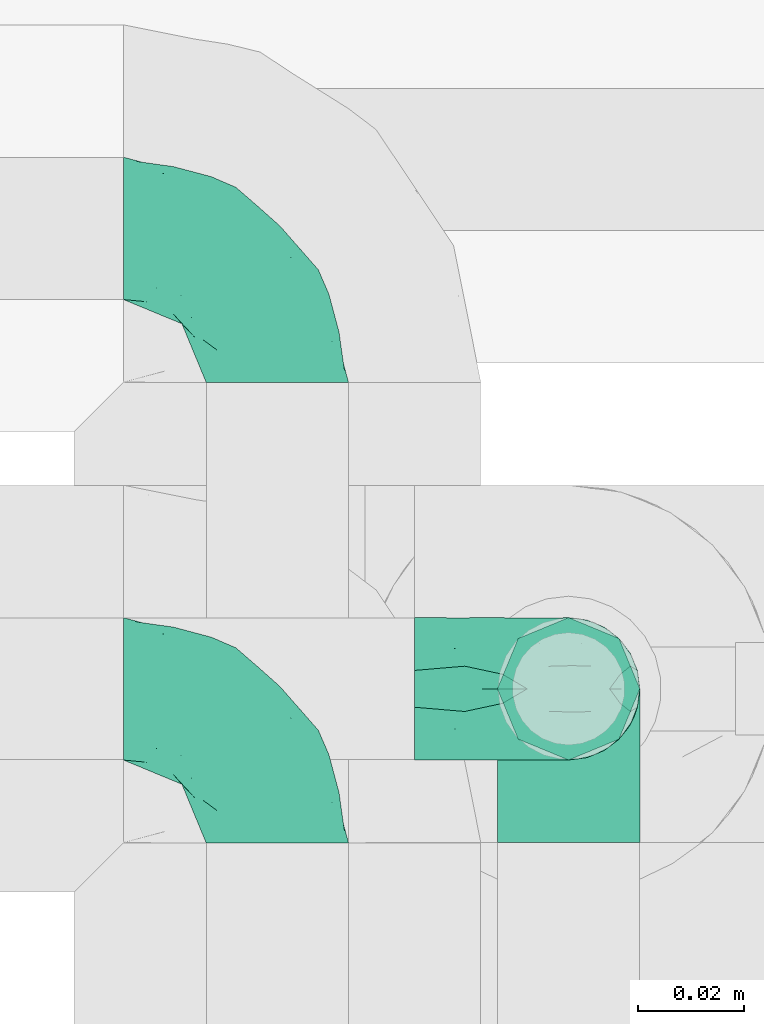
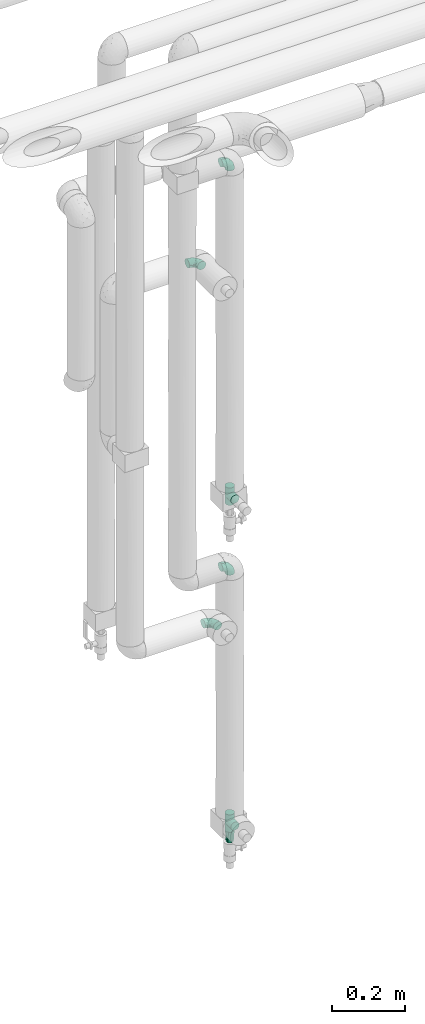
# One storey, part 757 of 824: 7 flow fittings.
"""IFC2X3 building model written with IfcOpenShell, lengths in millimetres."""

import ifcopenshell
import ifcopenshell.guid

model = None  # the IFC model being written
_history = None  # IfcOwnerHistory: only IFC2X3 demands one
_inside = {}  # id of a spatial element -> (the spatial element, [elements in it])
_under = {}  # id of a project, library or spatial element -> (it, [spatial elements below it])
_declared = {}  # id of a project -> (the project, [libraries it declares])
_typed = {}  # id of a type object -> (the type object, [elements of that type])
_made_of = {}  # id of a material, layer set ... -> (it, [elements and type objects made of it])


def new_model(schema):
    """Start an empty IFC model of exactly this schema.

    Asked for "IFC4X3", IfcOpenShell would pick the latest addendum, in which some entities
    have other attributes; the version numbers below select the first issue.
    IFC2X3 requires an IfcOwnerHistory on every rooted entity: one is made here for all.
    """
    global model, _history
    if schema == "IFC4X3":
        model = ifcopenshell.file(schema_version=(4, 3, 0, 0))
    else:
        model = ifcopenshell.file(schema=schema)
    _inside.clear()
    _under.clear()
    _declared.clear()
    _typed.clear()
    _made_of.clear()
    _history = None
    if model.schema == "IFC2X3":
        org = make("IfcOrganization", Name="unknown")
        user = make(
            "IfcPersonAndOrganization",
            ThePerson=make("IfcPerson", FamilyName="unknown"),
            TheOrganization=org,
        )
        app = make(
            "IfcApplication",
            ApplicationDeveloper=org,
            Version="unknown",
            ApplicationFullName="unknown",
            ApplicationIdentifier="unknown",
        )
        _history = make(
            "IfcOwnerHistory",
            OwningUser=user,
            OwningApplication=app,
            ChangeAction="ADDED",
            CreationDate=0,
        )
    return model


def make(cls, **values):
    """One entity of the class cls with the attributes given. An attribute that is None is left unset."""
    return model.create_entity(
        cls, **{name: value for name, value in values.items() if value is not None}
    )


def entity(cls, *values):
    """Any entity or typed value of the class cls, its attributes in the order of the schema. None: left unset."""
    e = model.create_entity(cls)
    for i, value in enumerate(values):
        if value is not None:
            e[i] = value
    return e


def rooted(cls, **values):
    """An entity with a GlobalId (a new one), such as an element, a storey or a relation."""
    return make(cls, GlobalId=ifcopenshell.guid.new(), OwnerHistory=_history, **values)


def si_unit(unit_type, name, prefix=None):
    """IfcSIUnit, for example si_unit("LENGTHUNIT", "METRE", prefix="MILLI")."""
    return make("IfcSIUnit", UnitType=unit_type, Prefix=prefix, Name=name)


def converted_unit(unit_type, name, factor, base, dimensions=None, offset=None):
    """IfcConversionBasedUnit, such as the inch: factor (a typed value) times the base unit."""
    return make(
        "IfcConversionBasedUnit"
        if offset is None
        else "IfcConversionBasedUnitWithOffset",
        ConversionOffset=offset,
        Dimensions=None
        if dimensions is None
        else entity("IfcDimensionalExponents", *dimensions),
        UnitType=unit_type,
        Name=name,
        ConversionFactor=make(
            "IfcMeasureWithUnit", ValueComponent=factor, UnitComponent=base
        ),
    )


def derived_unit(unit_type, elements):
    """IfcDerivedUnit: a product of units, each with its exponent."""
    return make(
        "IfcDerivedUnit",
        Elements=[
            make("IfcDerivedUnitElement", Unit=unit, Exponent=power)
            for unit, power in elements
        ],
        UnitType=unit_type,
    )


def assignment(units):
    """IfcUnitAssignment: the units of a project."""
    return None if units is None else make("IfcUnitAssignment", Units=units)


def point(xyz):
    """IfcCartesianPoint."""
    return None if xyz is None else make("IfcCartesianPoint", Coordinates=xyz)


def direction(xyz):
    """IfcDirection."""
    return None if xyz is None else make("IfcDirection", DirectionRatios=xyz)


def frame(location, z_axis=None, x_axis=None):
    """IfcAxis2Placement3D, a coordinate frame: its origin and axes. An axis left out is left unset."""
    return make(
        "IfcAxis2Placement3D",
        Location=point(location),
        Axis=direction(z_axis),
        RefDirection=direction(x_axis),
    )


def origin():
    """The frame at (0, 0, 0) with its axes left unset."""
    return frame((0.0, 0.0, 0.0))


def place(relative_to, where):
    """IfcLocalPlacement: puts the frame where relative to a parent placement (None: the world)."""
    return make(
        "IfcLocalPlacement", PlacementRelTo=relative_to, RelativePlacement=where
    )


def context(
    kind, dimensions, precision=None, world=None, true_north=None, identifier=None
):
    """IfcGeometricRepresentationContext, for example the 3D "Model" context."""
    return make(
        "IfcGeometricRepresentationContext",
        ContextIdentifier=identifier,
        ContextType=kind,
        CoordinateSpaceDimension=dimensions,
        Precision=precision,
        WorldCoordinateSystem=world,
        TrueNorth=true_north,
    )


def subcontext(parent, identifier, kind, view, scale=None):
    """IfcGeometricRepresentationSubContext, for example "Body" below "Model"."""
    return make(
        "IfcGeometricRepresentationSubContext",
        ContextIdentifier=identifier,
        ContextType=kind,
        ParentContext=parent,
        TargetScale=scale,
        TargetView=view,
    )


def project(units=None, contexts=None):
    """IfcProject with its units and contexts."""
    return rooted(
        "IfcProject",
        Name="project",
        RepresentationContexts=contexts,
        UnitsInContext=assignment(units),
    )


def spatial(cls, under=None, at=None, **own):
    """A site, building, storey or space (cls), placed at a placement, below another one or the project."""
    s = rooted(cls, ObjectPlacement=at, **own)
    if under is not None:
        _under.setdefault(under.id(), (under, []))[1].append(s)
    return s


def faces_of(points, faces, orient=None, outer=None):
    """IfcFace entities. A face is a list of loops; a loop is a list of indices into points, from 0.

    orient and outer hold one flag for each loop. By default every Orientation is true, the
    first loop of a face is its IfcFaceOuterBound and the others are IfcFaceBound.
    """
    made = []
    for i, loops in enumerate(faces):
        bounds = []
        for j, loop in enumerate(loops):
            is_outer = j == 0 if outer is None else outer[i][j]
            bounds.append(
                make(
                    "IfcFaceOuterBound" if is_outer else "IfcFaceBound",
                    Bound=make("IfcPolyLoop", Polygon=[points[k] for k in loop]),
                    Orientation=True if orient is None else orient[i][j],
                )
            )
        made.append(make("IfcFace", Bounds=bounds))
    return made


def faceted_brep(points, faces, orient=None, outer=None, voids=None):
    """IfcFacetedBrep: a solid bounded by flat faces; with voids (closed shells), ...WithVoids."""
    shared = [point(p) for p in points]
    hull = make("IfcClosedShell", CfsFaces=faces_of(shared, faces, orient, outer))
    if voids is None:
        return make("IfcFacetedBrep", Outer=hull)
    return make(
        "IfcFacetedBrepWithVoids",
        Outer=hull,
        Voids=[
            make(cls, CfsFaces=faces_of(shared, fs, o, b)) for cls, fs, o, b in voids
        ],
    )


def shape(context_of_items, identifier, shape_type, items):
    """IfcShapeRepresentation: the items that make up one representation, for example the "Body"."""
    return make(
        "IfcShapeRepresentation",
        ContextOfItems=context_of_items,
        RepresentationIdentifier=identifier,
        RepresentationType=shape_type,
        Items=items,
    )


def source(mapping_origin, context_of_items, identifier, shape_type, items):
    """IfcRepresentationMap: a shape defined once, which mapped items show again and again."""
    return make(
        "IfcRepresentationMap",
        MappingOrigin=mapping_origin,
        MappedRepresentation=shape(context_of_items, identifier, shape_type, items),
    )


def transform(
    local_origin,
    x_axis=None,
    y_axis=None,
    z_axis=None,
    scale=None,
    scale2=None,
    scale3=None,
    uniform=True,
):
    """IfcCartesianTransformationOperator3D, or its non-uniform kind. x_axis, y_axis, z_axis: its Axis1, 2, 3."""
    if uniform:
        return make(
            "IfcCartesianTransformationOperator3D",
            Axis1=direction(x_axis),
            Axis2=direction(y_axis),
            LocalOrigin=point(local_origin),
            Scale=scale,
            Axis3=direction(z_axis),
        )
    return make(
        "IfcCartesianTransformationOperator3DnonUniform",
        Axis1=direction(x_axis),
        Axis2=direction(y_axis),
        LocalOrigin=point(local_origin),
        Scale=scale,
        Axis3=direction(z_axis),
        Scale2=scale2,
        Scale3=scale3,
    )


def mapped(mapping_source, mapping_target):
    """IfcMappedItem: shows the shape of a source again, moved by a transform."""
    return make(
        "IfcMappedItem", MappingSource=mapping_source, MappingTarget=mapping_target
    )


def material(Name=None, Category=None):
    """IfcMaterial."""
    return make("IfcMaterial", Name=Name, Category=Category)


def made_of(thing, what):
    """Note that an element or type object is made of a material, layer set ...; save() writes the relation."""
    if what is not None:
        _made_of.setdefault(what.id(), (what, []))[1].append(thing)
    return thing


def type_object(cls, material=None, **own):
    """A type object (cls), such as IfcWallType, which elements share."""
    return made_of(rooted(cls, **own), material)


def type_shapes(of_type, sources):
    """Give a type object the sources (RepresentationMaps) that its elements show as mapped items."""
    of_type.RepresentationMaps = sources


def element(
    cls,
    number,
    at=None,
    inside=None,
    cuts=None,
    type_object=None,
    material=None,
    context=None,
    identifier="Body",
    shape_type=None,
    held_by="IfcProductDefinitionShape",
    body=None,
    shapes=None,
    **own,
):
    """One element of the class cls, such as IfcWall. Its Tag is "e" and its number.

    at: its placement. inside: the storey or other place that contains it. cuts: it is an
    opening in that element (IfcRelVoidsElement). A single representation is given by context,
    identifier, shape_type and body (its items); several are given by shapes. held_by: the class
    of the entity that holds the representations. save() writes the other relations.
    """
    e = rooted(cls, Tag="e%d" % number, ObjectPlacement=at, **own)
    if body is not None:
        shapes = [shape(context, identifier, shape_type, body)]
    if shapes is not None:
        e.Representation = make(held_by, Representations=shapes)
    if inside is not None:
        _inside.setdefault(inside.id(), (inside, []))[1].append(e)
    if cuts is not None:
        rooted(
            "IfcRelVoidsElement", RelatingBuildingElement=cuts, RelatedOpeningElement=e
        )
    if type_object is not None:
        _typed.setdefault(type_object.id(), (type_object, []))[1].append(e)
    return made_of(e, material)


def aggregate(whole, parts):
    """IfcRelAggregates: a whole, such as a stair, and the parts it consists of."""
    return rooted("IfcRelAggregates", RelatingObject=whole, RelatedObjects=parts)


def save(model, path):
    """Write the relations noted so far, then the file.

    IfcRelAggregates (storeys below a building ...), IfcRelContainedInSpatialStructure (elements
    in a storey), IfcRelDefinesByType, IfcRelAssociatesMaterial and IfcRelDeclares: one each for
    every whole, place, type object, material and project.
    """
    for whole, parts in _under.values():
        aggregate(whole, parts)
    for where, things in _inside.values():
        rooted(
            "IfcRelContainedInSpatialStructure",
            RelatedElements=things,
            RelatingStructure=where,
        )
    for kind, things in _typed.values():
        rooted("IfcRelDefinesByType", RelatedObjects=things, RelatingType=kind)
    for what, things in _made_of.values():
        rooted("IfcRelAssociatesMaterial", RelatedObjects=things, RelatingMaterial=what)
    for by, libraries in _declared.values():
        rooted("IfcRelDeclares", RelatingContext=by, RelatedDefinitions=libraries)
    model.write(path)


model = new_model("IFC2X3")

# Units and contexts
model_context = context("Model", 3, precision=0.01, world=origin(), true_north=direction((6.12303176911189e-17, 1.0)))
body_context = subcontext(model_context, "Body", "Model", "MODEL_VIEW")
ifc_project = project(units=[si_unit("LENGTHUNIT", "METRE", prefix="MILLI"), si_unit("AREAUNIT", "SQUARE_METRE"), si_unit("VOLUMEUNIT", "CUBIC_METRE"), converted_unit("PLANEANGLEUNIT", "DEGREE", entity("IfcRatioMeasure", 0.0174532925199433), si_unit("PLANEANGLEUNIT", "RADIAN"), dimensions=[0, 0, 0, 0, 0, 0, 0]), si_unit("MASSUNIT", "GRAM", prefix="KILO"), derived_unit("MASSDENSITYUNIT", [(si_unit("MASSUNIT", "GRAM", prefix="KILO"), 1), (si_unit("LENGTHUNIT", "METRE"), -3)]), derived_unit("MOMENTOFINERTIAUNIT", [(si_unit("LENGTHUNIT", "METRE"), 4)]), si_unit("TIMEUNIT", "SECOND"), si_unit("FREQUENCYUNIT", "HERTZ"), si_unit("THERMODYNAMICTEMPERATUREUNIT", "DEGREE_CELSIUS"), derived_unit("THERMALTRANSMITTANCEUNIT", [(si_unit("MASSUNIT", "GRAM", prefix="KILO"), 1), (si_unit("THERMODYNAMICTEMPERATUREUNIT", "KELVIN"), -1), (si_unit("TIMEUNIT", "SECOND"), -3)]), derived_unit("VOLUMETRICFLOWRATEUNIT", [(si_unit("LENGTHUNIT", "METRE"), 3), (si_unit("TIMEUNIT", "SECOND"), -1)]), derived_unit("MASSFLOWRATEUNIT", [(si_unit("MASSUNIT", "GRAM", prefix="KILO"), 1), (si_unit("TIMEUNIT", "SECOND"), -1)]), derived_unit("ROTATIONALFREQUENCYUNIT", [(si_unit("TIMEUNIT", "SECOND"), -1)]), si_unit("ELECTRICCURRENTUNIT", "AMPERE"), si_unit("ELECTRICVOLTAGEUNIT", "VOLT"), si_unit("POWERUNIT", "WATT"), si_unit("FORCEUNIT", "NEWTON", prefix="KILO"), si_unit("ILLUMINANCEUNIT", "LUX"), si_unit("LUMINOUSFLUXUNIT", "LUMEN"), si_unit("LUMINOUSINTENSITYUNIT", "CANDELA"), derived_unit("USERDEFINED", [(si_unit("MASSUNIT", "GRAM", prefix="KILO"), -1), (si_unit("LENGTHUNIT", "METRE"), -2), (si_unit("TIMEUNIT", "SECOND"), 3), (si_unit("LUMINOUSFLUXUNIT", "LUMEN"), 1)]), derived_unit("LINEARVELOCITYUNIT", [(si_unit("LENGTHUNIT", "METRE"), 1), (si_unit("TIMEUNIT", "SECOND"), -1)]), si_unit("PRESSUREUNIT", "PASCAL"), derived_unit("USERDEFINED", [(si_unit("LENGTHUNIT", "METRE"), -2), (si_unit("MASSUNIT", "GRAM", prefix="KILO"), 1), (si_unit("TIMEUNIT", "SECOND"), -2)]), derived_unit("LINEARFORCEUNIT", [(si_unit("MASSUNIT", "GRAM", prefix="KILO"), 1), (si_unit("LENGTHUNIT", "METRE"), 1), (si_unit("TIMEUNIT", "SECOND"), -2), (si_unit("LENGTHUNIT", "METRE"), -1)]), derived_unit("PLANARFORCEUNIT", [(si_unit("MASSUNIT", "GRAM", prefix="KILO"), 1), (si_unit("LENGTHUNIT", "METRE"), 1), (si_unit("TIMEUNIT", "SECOND"), -2), (si_unit("LENGTHUNIT", "METRE"), -2)])], contexts=[model_context])

# Site, building, storey
site_placement = place(None, origin())
site = spatial("IfcSite", under=ifc_project, at=site_placement, CompositionType="ELEMENT")
building_placement = place(site_placement, origin())
building = spatial("IfcBuilding", under=site, at=building_placement, CompositionType="ELEMENT")
storey_placement = place(building_placement, frame((0.0, 0.0, 28200.0)))
storey = spatial("IfcBuildingStorey", under=building, at=storey_placement, CompositionType="ELEMENT", Elevation=28200.0)

# Flow fittings
ifc_material = material()
pipe_fitting_type_1 = type_object("IfcPipeFittingType", PredefinedType="NOTDEFINED", material=ifc_material)
shared_shape_1 = source(origin(), body_context, "Body", "Brep", [
    faceted_brep([(-29.1, 0.0, -13.45), (-29.1, -3.48, -12.99), (-29.1, -6.73, -11.65), (-29.1, -9.51, -9.51), (-29.1, -11.65, -6.73), (-29.1, -12.99, -3.48), (-29.1, -13.45, 0.0), (-29.1, -12.99, 3.48), (-29.1, -11.65, 6.72), (-29.1, -9.51, 9.51), (-29.1, -6.73, 11.65), (-29.1, -3.48, 12.99), (-29.1, 0.0, 13.45), (-29.1, 3.48, 12.99), (-29.1, 6.72, 11.65), (-29.1, 9.51, 9.51), (-29.1, 11.65, 6.72), (-29.1, 12.99, 3.48), (-29.1, 13.45, 0.0), (-29.1, 12.99, -3.48), (-29.1, 11.65, -6.73), (-29.1, 9.51, -9.51), (-29.1, 6.72, -11.65), (-29.1, 3.48, -12.99), (-3.48, 29.1, -12.99), (-6.72, 29.1, -11.65), (-9.51, 29.1, -9.51), (-11.65, 29.1, -6.73), (-12.99, 29.1, -3.48), (-13.45, 29.1, 0.0), (-12.99, 29.1, 3.48), (-11.65, 29.1, 6.72), (-9.51, 29.1, 9.51), (-6.72, 29.1, 11.65), (-3.48, 29.1, 12.99), (0.0, 29.1, 13.45), (3.48, 29.1, 12.99), (6.73, 29.1, 11.65), (9.51, 29.1, 9.51), (11.65, 29.1, 6.72), (12.99, 29.1, 3.48), (13.45, 29.1, 0.0), (12.99, 29.1, -3.48), (11.65, 29.1, -6.73), (9.51, 29.1, -9.51), (6.73, 29.1, -11.65), (3.48, 29.1, -12.99), (0.0, 29.1, -13.45), (-19.62, -11.66, 4.28), (-21.41, -10.36, 7.6), (-16.26, -10.01, 0.0), (-12.48, -9.76, 2.75), (-10.66, 15.6, 11.91), (-15.27, 9.55, 12.42), (-10.71, 10.71, 13.09), (-0.04, 0.04, 0.0), (0.49, -0.45, 4.38), (-3.67, -4.15, 4.26), (-22.68, -11.73, 0.0), (-21.45, -4.97, 12.13), (-11.59, -2.84, 11.28), (-14.77, 0.17, 13.07), (-19.08, -7.58, 10.06), (-22.36, -1.69, 13.23), (-20.49, 2.21, 13.42), (-7.82, -7.75, 0.0), (-5.53, -2.55, 8.58), (-1.33, -0.87, 6.53), (-1.15, 1.15, 8.49), (-22.46, 5.38, 12.69), (-14.04, 21.05, 6.04), (-3.19, 3.19, 11.14), (-5.08, 25.05, 12.59), (-1.97, 21.79, 13.41), (-22.68, 11.31, 8.78), (-18.16, 12.64, 9.68), (-20.46, 14.33, 6.11), (-4.13, 10.11, 13.26), (-7.66, 3.08, 12.63), (-2.02, 8.24, 12.45), (-24.91, 8.22, 10.95), (-5.08, 14.28, 13.42), (-8.96, 6.48, 13.4), (-19.7, 16.14, 3.1), (-18.03, 18.03, 0.0), (-23.05, 15.96, 0.0), (-25.26, 12.69, 5.56), (4.97, 21.45, 12.13), (7.58, 19.08, 10.06), (1.69, 22.36, 13.23), (10.36, 21.41, 7.6), (8.11, 12.69, 6.86), (11.66, 19.62, 4.28), (-6.03, 19.65, 12.79), (9.76, 12.48, 2.75), (10.01, 16.26, 0.0), (-14.58, 16.06, 9.44), (-11.19, 23.14, 8.74), (-16.29, 16.8, 7.24), (-11.99, -5.68, 9.36), (-15.42, 20.78, 3.08), (5.79, 12.02, 9.27), (2.84, 11.59, 11.28), (2.55, 5.53, 8.58), (-15.74, 23.57, 0.0), (-15.96, 23.05, 0.0), (-24.62, 13.88, 2.39), (-8.61, 22.49, 11.12), (-14.98, 12.8, 11.14), (11.73, 22.68, 0.0), (-12.69, -8.11, 6.86), (7.75, 7.82, 0.0), (-15.98, 6.12, 13.19), (-14.48, 3.64, 13.45), (-19.6, 9.46, 11.31), (-8.3, 15.02, 12.85), (-0.17, 14.77, 13.07), (-6.9, -5.2, 6.52), (7.5, 8.93, 4.46), (5.22, 6.95, 6.56), (-8.85, -7.47, 4.42), (3.86, 3.93, 0.0), (4.18, 3.75, 4.31), (-23.57, 15.74, 0.0), (-3.93, -3.86, 0.0), (-21.79, 1.97, -13.41), (-11.31, 22.68, -8.78), (-14.33, 20.46, -6.11), (-12.69, 25.26, -5.56), (4.97, 21.45, -12.13), (2.84, 11.59, -11.28), (-0.17, 14.77, -13.07), (-25.05, 5.08, -12.59), (-16.8, 16.29, -7.24), (-20.78, 15.42, -3.08), (-16.14, 19.7, -3.1), (-12.02, -5.79, -9.27), (-11.59, -2.84, -11.28), (-5.53, -2.55, -8.58), (-23.14, 11.19, -8.74), (-22.49, 8.61, -11.12), (-1.33, -0.87, -6.53), (-3.67, -4.15, -4.26), (-6.9, -5.2, -6.52), (-19.65, 6.03, -12.79), (-15.6, 10.66, -11.91), (-14.28, 5.08, -13.42), (-10.71, 10.71, -13.09), (-6.48, 8.96, -13.4), (-19.62, -11.66, -4.28), (-21.41, -10.36, -7.6), (-12.48, -9.76, -2.75), (11.66, 19.62, -4.28), (-12.69, -8.11, -6.86), (-22.36, -1.69, -13.23), (-16.06, 14.58, -9.44), (5.68, 11.99, -9.36), (7.58, 19.08, -10.06), (-19.08, -7.58, -10.06), (-21.45, -4.97, -12.13), (-9.55, 15.27, -12.42), (-12.8, 14.98, -11.14), (-8.22, 24.91, -10.95), (10.36, 21.41, -7.6), (-5.38, 22.46, -12.69), (1.69, 22.36, -13.23), (-2.21, 20.49, -13.42), (-12.64, 18.16, -9.68), (-21.05, 14.04, -6.04), (9.76, 12.48, -2.75), (-10.11, 4.13, -13.26), (-3.08, 7.66, -12.63), (-8.24, 2.02, -12.45), (-13.88, 24.62, -2.39), (8.11, 12.69, -6.86), (-6.12, 15.98, -13.19), (-3.64, 14.48, -13.45), (-9.46, 19.6, -11.31), (-15.02, 8.3, -12.85), (-14.77, 0.17, -13.07), (-3.19, 3.19, -11.14), (5.22, 6.95, -6.56), (2.55, 5.53, -8.58), (0.49, -0.45, -4.38), (4.18, 3.75, -4.31), (-8.85, -7.47, -4.42), (-1.15, 1.15, -8.49), (7.5, 8.93, -4.46)], [[[0, 1, 2, 3, 4, 5, 6, 7, 8, 9, 10, 11, 12, 13, 14, 15, 16, 17, 18, 19, 20, 21, 22, 23]], [[24, 25, 26, 27, 28, 29, 30, 31, 32, 33, 34, 35, 36, 37, 38, 39, 40, 41, 42, 43, 44, 45, 46, 47]], [[48, 49, 8]], [[48, 50, 51]], [[52, 53, 54]], [[55, 56, 57]], [[49, 9, 8]], [[58, 48, 7]], [[59, 60, 61]], [[62, 10, 9]], [[62, 59, 10]], [[12, 63, 64]], [[51, 50, 65]], [[66, 67, 68]], [[12, 11, 63]], [[69, 14, 13]], [[31, 30, 70]], [[66, 71, 60]], [[34, 72, 73]], [[74, 75, 76]], [[77, 78, 79]], [[14, 80, 15]], [[16, 15, 74]], [[81, 54, 82]], [[83, 84, 85]], [[74, 76, 86]], [[37, 87, 88]], [[88, 38, 37]], [[36, 35, 89]], [[90, 91, 92]], [[93, 81, 73]], [[35, 34, 73]], [[10, 59, 11]], [[92, 94, 95]], [[96, 97, 98]], [[90, 92, 39]], [[99, 60, 62]], [[40, 39, 92]], [[87, 37, 36]], [[100, 84, 83]], [[50, 48, 58]], [[100, 83, 98]], [[101, 102, 103]], [[104, 105, 84, 100, 29]], [[48, 8, 7]], [[86, 17, 16]], [[106, 18, 17]], [[32, 97, 107]], [[53, 52, 108]], [[52, 93, 107]], [[97, 96, 107]], [[72, 107, 93]], [[72, 34, 33]], [[92, 109, 40]], [[33, 32, 107]], [[69, 13, 64]], [[88, 87, 102]], [[12, 64, 13]], [[49, 110, 62]], [[39, 38, 90]], [[95, 94, 111]], [[112, 113, 82]], [[53, 69, 112]], [[80, 74, 15]], [[114, 108, 75]], [[32, 31, 97]], [[115, 52, 54]], [[93, 115, 81]], [[89, 73, 116]], [[106, 76, 83]], [[106, 83, 85]], [[83, 76, 98]], [[100, 30, 29]], [[60, 59, 62]], [[63, 59, 61]], [[110, 117, 99]], [[60, 71, 78]], [[89, 87, 36]], [[116, 79, 102]], [[116, 102, 87]], [[102, 71, 103]], [[110, 49, 48]], [[62, 9, 49]], [[38, 88, 90]], [[91, 90, 88]], [[112, 69, 64]], [[80, 69, 114]], [[111, 94, 118]], [[119, 101, 103]], [[117, 66, 99]], [[117, 120, 57]], [[119, 91, 101]], [[66, 68, 71]], [[66, 117, 67]], [[121, 111, 122, 55]], [[56, 55, 122]], [[31, 70, 97]], [[97, 70, 98]], [[107, 96, 52]], [[53, 108, 114]], [[112, 82, 54]], [[116, 73, 81]], [[78, 82, 61]], [[81, 82, 77]], [[73, 89, 35]], [[87, 89, 116]], [[59, 63, 11]], [[64, 63, 61]], [[112, 64, 113]], [[53, 112, 54]], [[7, 6, 58]], [[109, 92, 95]], [[109, 41, 40]], [[69, 53, 114]], [[52, 96, 108]], [[75, 108, 96]], [[75, 96, 98]], [[114, 75, 74]], [[64, 61, 113]], [[61, 82, 113]], [[91, 88, 101]], [[110, 48, 51]], [[92, 91, 94]], [[91, 119, 118]], [[106, 85, 123, 18]], [[106, 17, 86]], [[60, 78, 61]], [[79, 78, 71]], [[102, 79, 71]], [[77, 79, 116]], [[81, 77, 116]], [[78, 77, 82]], [[69, 80, 14]], [[74, 80, 114]], [[74, 86, 16]], [[106, 86, 76]], [[107, 72, 33]], [[73, 72, 93]], [[98, 70, 100]], [[75, 98, 76]], [[30, 100, 70]], [[110, 99, 62]], [[66, 60, 99]], [[120, 110, 51]], [[67, 117, 57]], [[57, 56, 67]], [[67, 122, 119]], [[110, 120, 117]], [[65, 120, 51]], [[57, 65, 124, 55]], [[122, 67, 56]], [[67, 103, 68]], [[71, 68, 103]], [[65, 57, 120]], [[102, 101, 88]], [[67, 119, 103]], [[118, 119, 122]], [[118, 122, 111]], [[91, 118, 94]], [[81, 115, 54]], [[93, 52, 115]], [[23, 125, 0]], [[126, 127, 128]], [[129, 130, 131]], [[23, 22, 132]], [[133, 134, 135]], [[136, 137, 138]], [[21, 139, 140]], [[141, 142, 143]], [[144, 140, 145]], [[143, 136, 138]], [[146, 147, 148]], [[144, 132, 140]], [[5, 4, 149]], [[4, 3, 150]], [[45, 129, 46]], [[151, 50, 149]], [[152, 43, 42]], [[42, 41, 109]], [[150, 149, 4]], [[153, 149, 150]], [[154, 1, 0]], [[139, 155, 140]], [[156, 130, 157]], [[149, 58, 5]], [[18, 123, 85, 84, 134]], [[158, 159, 137]], [[84, 105, 135]], [[160, 145, 161]], [[143, 153, 136]], [[27, 26, 126]], [[25, 162, 26]], [[152, 163, 43]], [[25, 24, 164]], [[47, 165, 166]], [[158, 3, 2]], [[167, 127, 126]], [[20, 19, 168]], [[47, 46, 165]], [[44, 157, 45]], [[23, 132, 125]], [[44, 43, 163]], [[158, 2, 159]], [[47, 166, 24]], [[129, 45, 157]], [[164, 24, 166]], [[134, 84, 135]], [[95, 169, 152]], [[22, 21, 140]], [[144, 146, 125]], [[109, 152, 42]], [[95, 152, 109]], [[170, 171, 172]], [[155, 139, 133]], [[28, 27, 128]], [[159, 2, 1]], [[173, 29, 28]], [[50, 151, 65]], [[169, 95, 111]], [[163, 174, 157]], [[175, 176, 148]], [[160, 164, 175]], [[162, 126, 26]], [[177, 161, 167]], [[21, 20, 139]], [[144, 145, 178]], [[144, 178, 146]], [[154, 125, 179]], [[173, 127, 135]], [[173, 135, 105]], [[135, 127, 133]], [[134, 19, 18]], [[154, 159, 1]], [[179, 172, 137]], [[179, 137, 159]], [[137, 180, 138]], [[130, 129, 157]], [[165, 129, 131]], [[174, 181, 156]], [[130, 180, 171]], [[3, 158, 150]], [[153, 150, 158]], [[174, 163, 152]], [[157, 44, 163]], [[175, 164, 166]], [[162, 164, 177]], [[130, 182, 180]], [[181, 141, 182]], [[55, 183, 184]], [[65, 151, 185]], [[183, 55, 142]], [[156, 181, 182]], [[180, 182, 186]], [[181, 187, 184]], [[65, 142, 55, 124]], [[20, 168, 139]], [[139, 168, 133]], [[140, 155, 145]], [[160, 161, 177]], [[175, 148, 147]], [[179, 125, 146]], [[171, 148, 131]], [[146, 148, 170]], [[125, 154, 0]], [[159, 154, 179]], [[129, 165, 46]], [[166, 165, 131]], [[175, 166, 176]], [[160, 175, 147]], [[58, 149, 50]], [[58, 6, 5]], [[145, 160, 147]], [[164, 160, 177]], [[145, 155, 161]], [[167, 161, 155]], [[167, 155, 133]], [[177, 167, 126]], [[166, 131, 176]], [[131, 148, 176]], [[149, 153, 151]], [[153, 143, 185]], [[145, 147, 178]], [[174, 152, 169]], [[173, 105, 104, 29]], [[173, 28, 128]], [[130, 171, 131]], [[172, 171, 180]], [[137, 172, 180]], [[170, 172, 179]], [[146, 170, 179]], [[171, 170, 148]], [[164, 162, 25]], [[126, 162, 177]], [[126, 128, 27]], [[173, 128, 127]], [[140, 132, 22]], [[125, 132, 144]], [[133, 168, 134]], [[167, 133, 127]], [[19, 134, 168]], [[153, 158, 136]], [[137, 136, 158]], [[141, 143, 138]], [[185, 143, 142]], [[186, 141, 138]], [[183, 142, 141]], [[185, 142, 65]], [[153, 185, 151]], [[180, 186, 138]], [[182, 141, 186]], [[141, 184, 183]], [[184, 111, 121, 55]], [[174, 156, 157]], [[182, 130, 156]], [[187, 174, 169]], [[141, 181, 184]], [[174, 187, 181]], [[111, 187, 169]], [[111, 184, 187]], [[146, 178, 147]]]),
])
type_shapes(pipe_fitting_type_1, [shared_shape_1])
for number, where, z_axis, x_axis in (
    (1, (34840.42, 18334.91, 1230.0), (0.0, 1.0, 0.0), (1.0, 0.0, 0.0)),
    (2, (34840.42, 18334.91, 2580.0), (0.0, -1.0, 0.0), (0.0, 0.0, 1.0)),
):
    element("IfcFlowFitting", number, at=place(storey_placement, frame(where, z_axis=z_axis, x_axis=x_axis)), inside=storey, type_object=pipe_fitting_type_1, material=ifc_material, context=body_context, shape_type="MappedRepresentation", body=[
        mapped(shared_shape_1, transform((0.0, 0.0, 0.0), scale=1.0)),
    ])
pipe_fitting_type_2 = type_object("IfcPipeFittingType", PredefinedType="NOTDEFINED", material=ifc_material)
shared_shape_2 = source(origin(), body_context, "Body", "Brep", [
    faceted_brep([(-29.0, 3.48, -12.99), (-29.0, 0.0, -13.45), (-29.0, -3.48, -12.99), (-29.0, -6.73, -11.65), (-29.0, -9.51, -9.51), (-29.0, -11.65, -6.73), (-29.0, -12.99, -3.48), (-29.0, -13.45, 0.0), (-29.0, -12.99, 3.48), (-29.0, -11.65, 6.72), (-29.0, -9.51, 9.51), (-29.0, -6.73, 11.65), (-29.0, -3.48, 12.99), (-29.0, 0.0, 13.45), (-29.0, 3.48, 12.99), (-29.0, 6.72, 11.65), (-29.0, 9.51, 9.51), (-29.0, 11.65, 6.72), (-29.0, 12.99, 3.48), (-29.0, 13.45, 0.0), (-29.0, 12.99, -3.48), (-29.0, 11.65, -6.73), (-29.0, 9.51, -9.51), (-29.0, 6.72, -11.65), (29.0, 11.65, -6.73), (29.0, 12.99, -3.48), (29.0, 13.45, 0.0), (29.0, 12.99, 3.48), (29.0, 11.65, 6.72), (29.0, 9.51, 9.51), (29.0, 6.72, 11.65), (29.0, 3.48, 12.99), (29.0, 0.0, 13.45), (29.0, -3.48, 12.99), (29.0, -6.73, 11.65), (29.0, -9.51, 9.51), (29.0, -11.65, 6.72), (29.0, -12.99, 3.48), (29.0, -13.45, 0.0), (29.0, -12.99, -3.48), (29.0, -11.65, -6.73), (29.0, -9.51, -9.51), (29.0, -6.73, -11.65), (29.0, -3.48, -12.99), (29.0, 0.0, -13.45), (29.0, 3.48, -12.99), (29.0, 6.72, -11.65), (29.0, 9.51, -9.51), (12.96, -12.96, 3.59), (13.45, -13.45, 0.0), (-13.45, -13.45, 0.0), (11.64, -11.64, 6.74), (7.54, -7.54, 11.14), (9.76, -9.76, 9.25), (-12.96, -12.96, 3.59), (-11.64, -11.64, 6.74), (-9.76, -9.76, 9.25), (-7.54, -7.54, 11.14), (-5.12, -5.12, 12.44), (5.12, -5.12, 12.44), (2.58, -2.58, 13.2), (0.0, 0.0, 13.45), (-2.58, -2.58, 13.2), (2.58, -2.58, -13.2), (0.0, 0.0, -13.45), (-2.58, -2.58, -13.2), (-5.12, -5.12, -12.44), (5.12, -5.12, -12.44), (7.54, -7.54, -11.14), (9.76, -9.76, -9.25), (11.64, -11.64, -6.74), (12.96, -12.96, -3.59), (-7.54, -7.54, -11.14), (-9.76, -9.76, -9.25), (-12.96, -12.96, -3.59), (-11.64, -11.64, -6.74), (-12.99, -29.0, -3.48), (-11.65, -29.0, -6.73), (-9.51, -29.0, -9.51), (-6.72, -29.0, -11.65), (-3.48, -29.0, -12.99), (0.0, -29.0, -13.45), (3.48, -29.0, -12.99), (6.73, -29.0, -11.65), (9.51, -29.0, -9.51), (11.65, -29.0, -6.73), (12.99, -29.0, -3.48), (13.45, -29.0, 0.0), (12.99, -29.0, 3.48), (11.65, -29.0, 6.72), (9.51, -29.0, 9.51), (6.73, -29.0, 11.65), (3.48, -29.0, 12.99), (0.0, -29.0, 13.45), (-3.48, -29.0, 12.99), (-6.72, -29.0, 11.65), (-9.51, -29.0, 9.51), (-11.65, -29.0, 6.72), (-12.99, -29.0, 3.48), (-13.45, -29.0, 0.0)], [[[0, 1, 2, 3, 4, 5, 6, 7, 8, 9, 10, 11, 12, 13, 14, 15, 16, 17, 18, 19, 20, 21, 22, 23]], [[24, 25, 26, 27, 28, 29, 30, 31, 32, 33, 34, 35, 36, 37, 38, 39, 40, 41, 42, 43, 44, 45, 46, 47]], [[37, 36, 48]], [[38, 37, 49]], [[50, 8, 7]], [[49, 37, 48]], [[36, 51, 48]], [[35, 34, 52]], [[51, 36, 53]], [[52, 53, 35]], [[53, 36, 35]], [[50, 54, 8]], [[8, 54, 9]], [[54, 55, 9]], [[56, 57, 10]], [[10, 9, 56]], [[10, 57, 11]], [[56, 9, 55]], [[11, 57, 58]], [[52, 34, 59]], [[60, 32, 61]], [[62, 61, 13]], [[59, 33, 60]], [[33, 59, 34]], [[60, 33, 32]], [[61, 32, 31, 14, 13]], [[28, 27, 18, 17]], [[16, 15, 30, 29]], [[17, 16, 29, 28]], [[31, 30, 15, 14]], [[19, 18, 27, 26]], [[62, 12, 58]], [[12, 62, 13]], [[58, 12, 11]], [[47, 22, 21, 24]], [[25, 20, 19, 26]], [[25, 24, 21, 20]], [[23, 22, 47, 46]], [[44, 43, 63]], [[44, 64, 1, 0, 45]], [[64, 44, 63]], [[1, 64, 65]], [[46, 45, 0, 23]], [[65, 66, 2]], [[1, 65, 2]], [[66, 3, 2]], [[63, 43, 67]], [[42, 41, 68]], [[69, 68, 41]], [[40, 70, 69]], [[69, 41, 40]], [[42, 68, 67]], [[39, 38, 49]], [[6, 50, 7]], [[39, 71, 40]], [[71, 39, 49]], [[40, 71, 70]], [[72, 3, 66]], [[72, 4, 3]], [[4, 72, 73]], [[4, 73, 5]], [[74, 50, 6]], [[75, 74, 5]], [[74, 6, 5]], [[75, 5, 73]], [[42, 67, 43]], [[76, 77, 78, 79, 80, 81, 82, 83, 84, 85, 86, 87, 88, 89, 90, 91, 92, 93, 94, 95, 96, 97, 98, 99]], [[99, 98, 50]], [[54, 50, 98]], [[96, 95, 57]], [[97, 96, 56]], [[97, 54, 98]], [[58, 95, 94]], [[55, 54, 97]], [[56, 55, 97]], [[58, 57, 95]], [[93, 61, 62]], [[58, 94, 62]], [[56, 96, 57]], [[62, 94, 93]], [[60, 93, 92]], [[91, 59, 92]], [[89, 88, 48]], [[53, 90, 89]], [[52, 91, 90]], [[49, 88, 87]], [[59, 60, 92]], [[52, 59, 91]], [[49, 48, 88]], [[51, 53, 89]], [[48, 51, 89]], [[52, 90, 53]], [[93, 60, 61]], [[87, 86, 49]], [[71, 49, 86]], [[69, 85, 84]], [[68, 84, 83]], [[86, 85, 71]], [[67, 83, 82]], [[70, 71, 85]], [[69, 70, 85]], [[67, 68, 83]], [[81, 64, 63]], [[67, 82, 63]], [[69, 84, 68]], [[63, 82, 81]], [[65, 81, 80]], [[79, 66, 80]], [[77, 76, 74]], [[73, 78, 77]], [[72, 79, 78]], [[50, 76, 99]], [[66, 65, 80]], [[72, 66, 79]], [[50, 74, 76]], [[75, 73, 77]], [[74, 75, 77]], [[72, 78, 73]], [[81, 65, 64]]]),
])
type_shapes(pipe_fitting_type_2, [shared_shape_2])
for number, where, z_axis, x_axis in (
    (3, (34840.42, 18334.91, 372.0), (1.0, 0.0, 0.0), (0.0, 0.0, -1.0)),
    (4, (34840.42, 18334.91, 1463.5), (1.0, 0.0, 0.0), (0.0, 0.0, -1.0)),
):
    element("IfcFlowFitting", number, at=place(storey_placement, frame(where, z_axis=z_axis, x_axis=x_axis)), inside=storey, type_object=pipe_fitting_type_2, material=ifc_material, context=body_context, shape_type="MappedRepresentation", body=[
        mapped(shared_shape_2, transform((0.0, 0.0, 0.0), scale=1.0)),
    ])
pipe_fitting_type_3 = type_object("IfcPipeFittingType", PredefinedType="NOTDEFINED", material=ifc_material)
shared_shape_3 = source(origin(), body_context, "Body", "Brep", [
    faceted_brep([(-29.1, -3.48, -12.99), (-29.1, -6.72, -11.65), (-29.1, -9.51, -9.51), (-29.1, -11.65, -6.73), (-29.1, -12.99, -3.48), (-29.1, -13.45, 0.0), (-29.1, -12.99, 3.48), (-29.1, -11.65, 6.72), (-29.1, -9.51, 9.51), (-29.1, -6.72, 11.65), (-29.1, -3.48, 12.99), (-29.1, 0.0, 13.45), (-29.1, 3.48, 12.99), (-29.1, 6.73, 11.65), (-29.1, 9.51, 9.51), (-29.1, 11.65, 6.72), (-29.1, 12.99, 3.48), (-29.1, 13.45, 0.0), (-29.1, 12.99, -3.48), (-29.1, 11.65, -6.73), (-29.1, 9.51, -9.51), (-29.1, 6.73, -11.65), (-29.1, 3.48, -12.99), (-29.1, 0.0, -13.45), (0.0, -29.1, -13.45), (3.48, -29.1, -12.99), (6.73, -29.1, -11.65), (9.51, -29.1, -9.51), (11.65, -29.1, -6.73), (12.99, -29.1, -3.48), (13.45, -29.1, 0.0), (12.99, -29.1, 3.48), (11.65, -29.1, 6.72), (9.51, -29.1, 9.51), (6.73, -29.1, 11.65), (3.48, -29.1, 12.99), (0.0, -29.1, 13.45), (-3.48, -29.1, 12.99), (-6.72, -29.1, 11.65), (-9.51, -29.1, 9.51), (-11.65, -29.1, 6.72), (-12.99, -29.1, 3.48), (-13.45, -29.1, 0.0), (-12.99, -29.1, -3.48), (-11.65, -29.1, -6.73), (-9.51, -29.1, -9.51), (-6.72, -29.1, -11.65), (-3.48, -29.1, -12.99), (-21.41, 10.36, 7.6), (-19.62, 11.66, 4.28), (-12.48, 9.76, 2.75), (-16.26, 10.01, 0.0), (-10.71, -10.71, 13.09), (-15.27, -9.55, 12.42), (-10.66, -15.6, 11.91), (-3.67, 4.15, 4.26), (0.49, 0.45, 4.38), (-0.04, -0.04, 0.0), (-22.68, 11.73, 0.0), (-14.77, -0.17, 13.07), (-11.59, 2.84, 11.28), (-21.45, 4.97, 12.13), (-19.08, 7.58, 10.06), (-20.49, -2.21, 13.42), (-22.36, 1.69, 13.23), (-7.82, 7.75, 0.0), (-1.15, -1.15, 8.49), (-1.33, 0.87, 6.53), (-5.53, 2.55, 8.58), (-22.46, -5.38, 12.69), (-14.04, -21.05, 6.04), (-3.19, -3.19, 11.14), (-1.97, -21.79, 13.41), (-5.08, -25.05, 12.59), (-20.46, -14.33, 6.11), (-18.16, -12.64, 9.68), (-22.68, -11.31, 8.78), (-2.02, -8.24, 12.45), (-7.66, -3.08, 12.63), (-4.13, -10.11, 13.26), (-24.91, -8.22, 10.95), (-8.96, -6.48, 13.4), (-5.08, -14.28, 13.42), (-23.05, -15.96, 0.0), (-18.03, -18.03, 0.0), (-19.7, -16.14, 3.1), (-25.26, -12.69, 5.56), (7.58, -19.08, 10.06), (4.97, -21.45, 12.13), (1.69, -22.36, 13.23), (11.66, -19.62, 4.28), (8.11, -12.69, 6.86), (10.36, -21.41, 7.6), (-6.03, -19.65, 12.79), (10.01, -16.26, 0.0), (9.76, -12.48, 2.75), (-16.29, -16.8, 7.24), (-11.19, -23.14, 8.74), (-14.58, -16.06, 9.44), (-11.99, 5.68, 9.36), (-15.42, -20.78, 3.08), (2.55, -5.53, 8.58), (2.84, -11.59, 11.28), (5.79, -12.02, 9.27), (-15.96, -23.05, 0.0), (-15.74, -23.57, 0.0), (-24.62, -13.88, 2.39), (-8.61, -22.49, 11.12), (-14.98, -12.8, 11.14), (11.73, -22.68, 0.0), (-12.69, 8.11, 6.86), (7.75, -7.82, 0.0), (-14.48, -3.64, 13.45), (-15.98, -6.12, 13.19), (-19.6, -9.46, 11.31), (-8.3, -15.02, 12.85), (-0.17, -14.77, 13.07), (-6.9, 5.2, 6.52), (7.5, -8.93, 4.46), (5.22, -6.95, 6.56), (-8.85, 7.47, 4.42), (4.18, -3.75, 4.31), (3.86, -3.93, 0.0), (-23.57, -15.74, 0.0), (-3.93, 3.86, 0.0), (-21.79, -1.97, -13.41), (-12.69, -25.26, -5.56), (-14.33, -20.46, -6.11), (-11.31, -22.68, -8.78), (-0.17, -14.77, -13.07), (2.84, -11.59, -11.28), (4.97, -21.45, -12.13), (-25.05, -5.08, -12.59), (-16.14, -19.7, -3.1), (-20.78, -15.42, -3.08), (-16.8, -16.29, -7.24), (-5.53, 2.55, -8.58), (-11.59, 2.84, -11.28), (-12.02, 5.79, -9.27), (-22.49, -8.61, -11.12), (-23.14, -11.19, -8.74), (-6.9, 5.2, -6.52), (-3.67, 4.15, -4.26), (-1.33, 0.87, -6.53), (-15.6, -10.66, -11.91), (-19.65, -6.03, -12.79), (-6.48, -8.96, -13.4), (-10.71, -10.71, -13.09), (-14.28, -5.08, -13.42), (-19.62, 11.66, -4.28), (-21.41, 10.36, -7.6), (-12.48, 9.76, -2.75), (11.66, -19.62, -4.28), (-12.69, 8.11, -6.86), (-22.36, 1.69, -13.23), (-16.06, -14.58, -9.44), (7.58, -19.08, -10.06), (5.68, -11.99, -9.36), (-21.45, 4.97, -12.13), (-19.08, 7.58, -10.06), (-12.8, -14.98, -11.14), (-9.55, -15.27, -12.42), (-8.22, -24.91, -10.95), (10.36, -21.41, -7.6), (-5.38, -22.46, -12.69), (-2.21, -20.49, -13.42), (1.69, -22.36, -13.23), (-12.64, -18.16, -9.68), (-21.05, -14.04, -6.04), (9.76, -12.48, -2.75), (-8.24, -2.02, -12.45), (-3.08, -7.66, -12.63), (-10.11, -4.13, -13.26), (-13.88, -24.62, -2.39), (8.11, -12.69, -6.86), (-3.64, -14.48, -13.45), (-6.12, -15.98, -13.19), (-9.46, -19.6, -11.31), (-15.02, -8.3, -12.85), (-14.77, -0.17, -13.07), (-3.19, -3.19, -11.14), (5.22, -6.95, -6.56), (2.55, -5.53, -8.58), (4.18, -3.75, -4.31), (0.49, 0.45, -4.38), (-8.85, 7.47, -4.42), (-1.15, -1.15, -8.49), (7.5, -8.93, -4.46)], [[[0, 1, 2, 3, 4, 5, 6, 7, 8, 9, 10, 11, 12, 13, 14, 15, 16, 17, 18, 19, 20, 21, 22, 23]], [[24, 25, 26, 27, 28, 29, 30, 31, 32, 33, 34, 35, 36, 37, 38, 39, 40, 41, 42, 43, 44, 45, 46, 47]], [[15, 48, 49]], [[50, 51, 49]], [[52, 53, 54]], [[55, 56, 57]], [[15, 14, 48]], [[16, 49, 58]], [[59, 60, 61]], [[14, 13, 62]], [[13, 61, 62]], [[63, 64, 11]], [[65, 51, 50]], [[66, 67, 68]], [[64, 12, 11]], [[10, 9, 69]], [[70, 41, 40]], [[60, 71, 68]], [[72, 73, 37]], [[74, 75, 76]], [[77, 78, 79]], [[8, 80, 9]], [[76, 8, 7]], [[81, 52, 82]], [[83, 84, 85]], [[86, 74, 76]], [[87, 88, 34]], [[34, 33, 87]], [[89, 36, 35]], [[90, 91, 92]], [[72, 82, 93]], [[72, 37, 36]], [[12, 61, 13]], [[94, 95, 90]], [[96, 97, 98]], [[32, 90, 92]], [[62, 60, 99]], [[90, 32, 31]], [[35, 34, 88]], [[85, 84, 100]], [[58, 49, 51]], [[96, 85, 100]], [[101, 102, 103]], [[42, 100, 84, 104, 105]], [[16, 15, 49]], [[7, 6, 86]], [[6, 5, 106]], [[107, 97, 39]], [[108, 54, 53]], [[107, 93, 54]], [[107, 98, 97]], [[93, 107, 73]], [[38, 37, 73]], [[31, 109, 90]], [[107, 39, 38]], [[63, 10, 69]], [[102, 88, 87]], [[10, 63, 11]], [[62, 110, 48]], [[92, 33, 32]], [[111, 95, 94]], [[81, 112, 113]], [[113, 69, 53]], [[8, 76, 80]], [[75, 108, 114]], [[97, 40, 39]], [[52, 54, 115]], [[82, 115, 93]], [[116, 72, 89]], [[85, 74, 106]], [[83, 85, 106]], [[96, 74, 85]], [[42, 41, 100]], [[62, 61, 60]], [[59, 61, 64]], [[99, 117, 110]], [[78, 71, 60]], [[35, 88, 89]], [[102, 77, 116]], [[88, 102, 116]], [[101, 71, 102]], [[49, 48, 110]], [[48, 14, 62]], [[92, 87, 33]], [[87, 92, 91]], [[63, 69, 113]], [[114, 69, 80]], [[118, 95, 111]], [[101, 103, 119]], [[99, 68, 117]], [[55, 120, 117]], [[103, 91, 119]], [[71, 66, 68]], [[67, 117, 68]], [[121, 111, 122, 57]], [[121, 57, 56]], [[97, 70, 40]], [[96, 70, 97]], [[54, 98, 107]], [[114, 108, 53]], [[52, 81, 113]], [[82, 72, 116]], [[59, 81, 78]], [[79, 81, 82]], [[36, 89, 72]], [[116, 89, 88]], [[12, 64, 61]], [[59, 64, 63]], [[112, 63, 113]], [[52, 113, 53]], [[58, 17, 16]], [[94, 90, 109]], [[31, 30, 109]], [[114, 53, 69]], [[108, 98, 54]], [[98, 108, 75]], [[96, 98, 75]], [[76, 75, 114]], [[112, 59, 63]], [[112, 81, 59]], [[103, 87, 91]], [[50, 49, 110]], [[95, 91, 90]], [[118, 119, 91]], [[106, 5, 123, 83]], [[86, 6, 106]], [[59, 78, 60]], [[71, 78, 77]], [[71, 77, 102]], [[116, 77, 79]], [[116, 79, 82]], [[81, 79, 78]], [[9, 80, 69]], [[114, 80, 76]], [[7, 86, 76]], [[74, 86, 106]], [[38, 73, 107]], [[93, 73, 72]], [[100, 70, 96]], [[74, 96, 75]], [[70, 100, 41]], [[62, 99, 110]], [[99, 60, 68]], [[50, 110, 120]], [[55, 117, 67]], [[67, 56, 55]], [[119, 121, 67]], [[117, 120, 110]], [[50, 120, 65]], [[124, 65, 55, 57]], [[56, 67, 121]], [[66, 101, 67]], [[101, 66, 71]], [[120, 55, 65]], [[87, 103, 102]], [[101, 119, 67]], [[121, 119, 118]], [[111, 121, 118]], [[95, 118, 91]], [[52, 115, 82]], [[115, 54, 93]], [[23, 125, 0]], [[126, 127, 128]], [[129, 130, 131]], [[132, 1, 0]], [[133, 134, 135]], [[136, 137, 138]], [[139, 140, 2]], [[141, 142, 143]], [[144, 139, 145]], [[136, 138, 141]], [[146, 147, 148]], [[139, 132, 145]], [[149, 19, 18]], [[150, 20, 19]], [[25, 131, 26]], [[149, 51, 151]], [[29, 28, 152]], [[109, 30, 29]], [[19, 149, 150]], [[150, 149, 153]], [[23, 22, 154]], [[139, 155, 140]], [[156, 130, 157]], [[18, 58, 149]], [[134, 84, 83, 123, 5]], [[137, 158, 159]], [[133, 104, 84]], [[160, 144, 161]], [[138, 153, 141]], [[128, 45, 44]], [[45, 162, 46]], [[28, 163, 152]], [[164, 47, 46]], [[165, 166, 24]], [[21, 20, 159]], [[128, 127, 167]], [[168, 4, 3]], [[166, 25, 24]], [[26, 156, 27]], [[125, 132, 0]], [[163, 28, 27]], [[158, 21, 159]], [[47, 165, 24]], [[156, 26, 131]], [[165, 47, 164]], [[133, 84, 134]], [[152, 169, 94]], [[139, 2, 1]], [[125, 148, 145]], [[29, 152, 109]], [[109, 152, 94]], [[170, 171, 172]], [[135, 140, 155]], [[126, 44, 43]], [[22, 21, 158]], [[43, 42, 173]], [[65, 151, 51]], [[111, 94, 169]], [[156, 174, 163]], [[146, 175, 176]], [[176, 164, 161]], [[45, 128, 162]], [[167, 160, 177]], [[140, 3, 2]], [[178, 144, 145]], [[148, 178, 145]], [[179, 125, 154]], [[133, 127, 173]], [[104, 133, 173]], [[135, 127, 133]], [[5, 4, 134]], [[22, 158, 154]], [[137, 170, 179]], [[158, 137, 179]], [[136, 180, 137]], [[156, 131, 130]], [[129, 131, 166]], [[157, 181, 174]], [[171, 180, 130]], [[150, 159, 20]], [[159, 150, 153]], [[152, 163, 174]], [[163, 27, 156]], [[165, 164, 176]], [[177, 164, 162]], [[180, 182, 130]], [[182, 143, 181]], [[183, 184, 57]], [[185, 151, 65]], [[142, 57, 184]], [[182, 181, 157]], [[186, 182, 180]], [[183, 187, 181]], [[124, 57, 142, 65]], [[140, 168, 3]], [[135, 168, 140]], [[144, 155, 139]], [[177, 160, 161]], [[147, 146, 176]], [[148, 125, 179]], [[129, 146, 171]], [[172, 146, 148]], [[23, 154, 125]], [[179, 154, 158]], [[25, 166, 131]], [[129, 166, 165]], [[175, 165, 176]], [[147, 176, 161]], [[51, 149, 58]], [[18, 17, 58]], [[147, 161, 144]], [[177, 161, 164]], [[160, 155, 144]], [[155, 160, 167]], [[135, 155, 167]], [[128, 167, 177]], [[175, 129, 165]], [[175, 146, 129]], [[151, 153, 149]], [[185, 141, 153]], [[178, 147, 144]], [[169, 152, 174]], [[173, 42, 105, 104]], [[126, 43, 173]], [[129, 171, 130]], [[180, 171, 170]], [[180, 170, 137]], [[179, 170, 172]], [[179, 172, 148]], [[146, 172, 171]], [[46, 162, 164]], [[177, 162, 128]], [[44, 126, 128]], [[127, 126, 173]], [[1, 132, 139]], [[145, 132, 125]], [[134, 168, 135]], [[127, 135, 167]], [[168, 134, 4]], [[138, 159, 153]], [[159, 138, 137]], [[136, 141, 143]], [[142, 141, 185]], [[136, 143, 186]], [[143, 142, 184]], [[65, 142, 185]], [[151, 185, 153]], [[136, 186, 180]], [[186, 143, 182]], [[184, 183, 143]], [[122, 111, 183, 57]], [[156, 157, 174]], [[157, 130, 182]], [[169, 174, 187]], [[183, 181, 143]], [[181, 187, 174]], [[169, 187, 111]], [[187, 183, 111]], [[147, 178, 148]]]),
])
type_shapes(pipe_fitting_type_3, [shared_shape_3])
for number, where in (
    (5, (34785.39, 18334.91, 1060.0)),
    (6, (34785.39, 18421.91, 2210.0)),
):
    element("IfcFlowFitting", number, at=place(storey_placement, frame(where)), inside=storey, type_object=pipe_fitting_type_3, material=ifc_material, context=body_context, shape_type="MappedRepresentation", body=[
        mapped(shared_shape_3, transform((0.0, 0.0, 0.0), scale=1.0)),
    ])
pipe_fitting_type_4 = type_object("IfcPipeFittingType", PredefinedType="NOTDEFINED", material=ifc_material)
shared_shape_4 = source(origin(), body_context, "Body", "Brep", [
    faceted_brep([(38.0, 9.51, 9.51), (38.0, 0.0, 13.45), (38.0, -9.51, 9.51), (38.0, -13.45, 0.0), (38.0, -9.51, -9.51), (38.0, 0.0, -13.45), (38.0, 9.51, -9.51), (38.0, 13.45, 0.0), (0.0, -10.65, 0.0), (0.0, -5.33, 9.22), (0.0, 5.33, 9.22), (0.0, 10.65, 0.0), (0.0, 5.32, -9.22), (0.0, -5.33, -9.22)], [[[0, 1, 2, 3, 4, 5, 6, 7]], [[8, 9, 10, 11, 12, 13]], [[8, 13, 4]], [[4, 3, 8]], [[13, 5, 4]], [[12, 11, 6]], [[6, 5, 12]], [[7, 6, 11]], [[12, 5, 13]], [[11, 10, 0]], [[0, 7, 11]], [[10, 1, 0]], [[9, 8, 2]], [[2, 1, 9]], [[3, 2, 8]], [[9, 1, 10]]]),
])
type_shapes(pipe_fitting_type_4, [shared_shape_4])
flow_fitting_placement = place(storey_placement, frame((34840.42, 18334.91, 305.0), z_axis=(1.0, 0.0, 0.0), x_axis=(0.0, 0.0, 1.0)))
element("IfcFlowFitting", 7, at=flow_fitting_placement, inside=storey, type_object=pipe_fitting_type_4, material=ifc_material, context=body_context, shape_type="MappedRepresentation", body=[
    mapped(shared_shape_4, transform((0.0, 0.0, 0.0), scale=1.0)),
])

save(model, "model.ifc")
